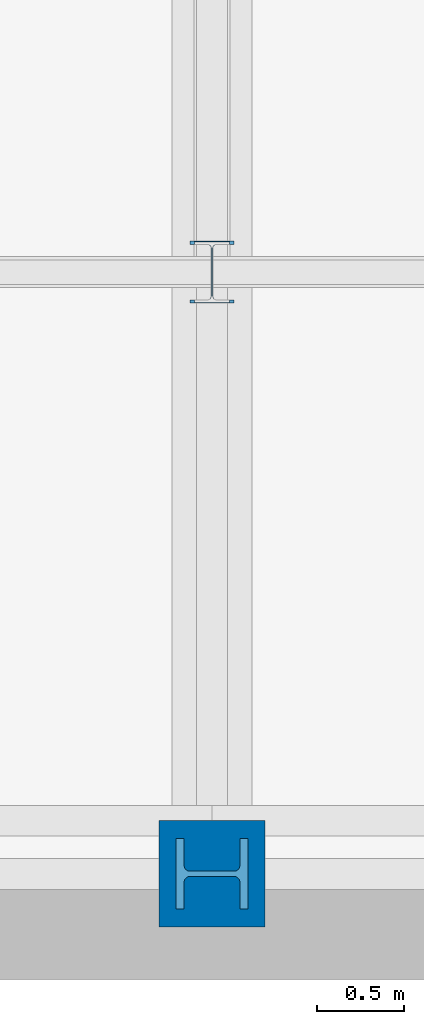
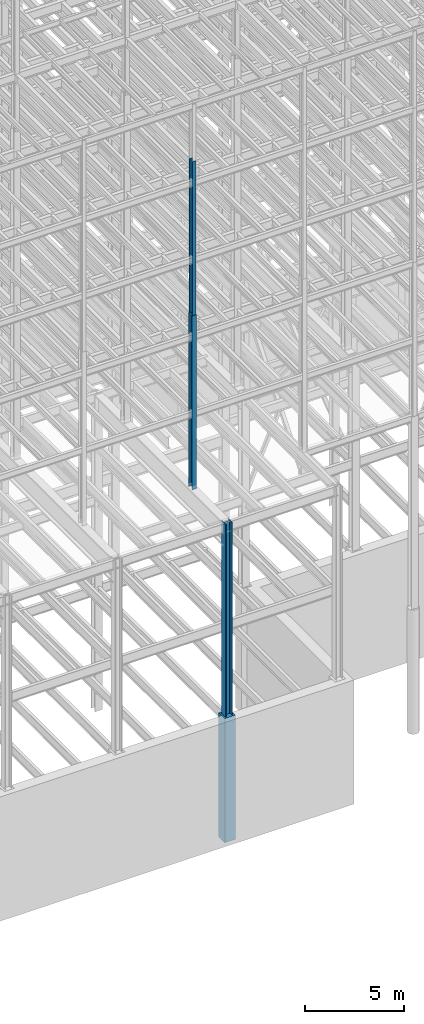
# One storey, part 22 of 150: 4 columns.
"""IFC2X3 building model written with IfcOpenShell, lengths in millimetres."""

import ifcopenshell
import ifcopenshell.guid

model = None  # the IFC model being written
_history = None  # IfcOwnerHistory: only IFC2X3 demands one
_inside = {}  # id of a spatial element -> (the spatial element, [elements in it])
_under = {}  # id of a project, library or spatial element -> (it, [spatial elements below it])
_declared = {}  # id of a project -> (the project, [libraries it declares])
_typed = {}  # id of a type object -> (the type object, [elements of that type])
_made_of = {}  # id of a material, layer set ... -> (it, [elements and type objects made of it])


def new_model(schema):
    """Start an empty IFC model of exactly this schema.

    Asked for "IFC4X3", IfcOpenShell would pick the latest addendum, in which some entities
    have other attributes; the version numbers below select the first issue.
    IFC2X3 requires an IfcOwnerHistory on every rooted entity: one is made here for all.
    """
    global model, _history
    if schema == "IFC4X3":
        model = ifcopenshell.file(schema_version=(4, 3, 0, 0))
    else:
        model = ifcopenshell.file(schema=schema)
    _inside.clear()
    _under.clear()
    _declared.clear()
    _typed.clear()
    _made_of.clear()
    _history = None
    if model.schema == "IFC2X3":
        org = make("IfcOrganization", Name="unknown")
        user = make(
            "IfcPersonAndOrganization",
            ThePerson=make("IfcPerson", FamilyName="unknown"),
            TheOrganization=org,
        )
        app = make(
            "IfcApplication",
            ApplicationDeveloper=org,
            Version="unknown",
            ApplicationFullName="unknown",
            ApplicationIdentifier="unknown",
        )
        _history = make(
            "IfcOwnerHistory",
            OwningUser=user,
            OwningApplication=app,
            ChangeAction="ADDED",
            CreationDate=0,
        )
    return model


def make(cls, **values):
    """One entity of the class cls with the attributes given. An attribute that is None is left unset."""
    return model.create_entity(
        cls, **{name: value for name, value in values.items() if value is not None}
    )


def rooted(cls, **values):
    """An entity with a GlobalId (a new one), such as an element, a storey or a relation."""
    return make(cls, GlobalId=ifcopenshell.guid.new(), OwnerHistory=_history, **values)


def si_unit(unit_type, name, prefix=None):
    """IfcSIUnit, for example si_unit("LENGTHUNIT", "METRE", prefix="MILLI")."""
    return make("IfcSIUnit", UnitType=unit_type, Prefix=prefix, Name=name)


def assignment(units):
    """IfcUnitAssignment: the units of a project."""
    return None if units is None else make("IfcUnitAssignment", Units=units)


def point(xyz):
    """IfcCartesianPoint."""
    return None if xyz is None else make("IfcCartesianPoint", Coordinates=xyz)


def direction(xyz):
    """IfcDirection."""
    return None if xyz is None else make("IfcDirection", DirectionRatios=xyz)


def frame(location, z_axis=None, x_axis=None):
    """IfcAxis2Placement3D, a coordinate frame: its origin and axes. An axis left out is left unset."""
    return make(
        "IfcAxis2Placement3D",
        Location=point(location),
        Axis=direction(z_axis),
        RefDirection=direction(x_axis),
    )


def frame_2d(location, x_axis=None):
    """IfcAxis2Placement2D, a coordinate frame in the plane: its origin and x axis."""
    return make(
        "IfcAxis2Placement2D", Location=point(location), RefDirection=direction(x_axis)
    )


def origin_with_axes():
    """The frame at (0, 0, 0) with the z axis (0, 0, 1) and the x axis (1, 0, 0) written out."""
    return frame((0.0, 0.0, 0.0), z_axis=(0.0, 0.0, 1.0), x_axis=(1.0, 0.0, 0.0))


def origin_2d_with_axis():
    """The frame at (0, 0) in the plane with the x axis (1, 0) written out."""
    return frame_2d((0.0, 0.0), x_axis=(1.0, 0.0))


def place(relative_to, where):
    """IfcLocalPlacement: puts the frame where relative to a parent placement (None: the world)."""
    return make(
        "IfcLocalPlacement", PlacementRelTo=relative_to, RelativePlacement=where
    )


def context(
    kind, dimensions, precision=None, world=None, true_north=None, identifier=None
):
    """IfcGeometricRepresentationContext, for example the 3D "Model" context."""
    return make(
        "IfcGeometricRepresentationContext",
        ContextIdentifier=identifier,
        ContextType=kind,
        CoordinateSpaceDimension=dimensions,
        Precision=precision,
        WorldCoordinateSystem=world,
        TrueNorth=true_north,
    )


def subcontext(parent, identifier, kind, view, scale=None):
    """IfcGeometricRepresentationSubContext, for example "Body" below "Model"."""
    return make(
        "IfcGeometricRepresentationSubContext",
        ContextIdentifier=identifier,
        ContextType=kind,
        ParentContext=parent,
        TargetScale=scale,
        TargetView=view,
    )


def project(units=None, contexts=None):
    """IfcProject with its units and contexts."""
    return rooted(
        "IfcProject",
        Name="project",
        RepresentationContexts=contexts,
        UnitsInContext=assignment(units),
    )


def spatial(cls, under=None, at=None, **own):
    """A site, building, storey or space (cls), placed at a placement, below another one or the project."""
    s = rooted(cls, ObjectPlacement=at, **own)
    if under is not None:
        _under.setdefault(under.id(), (under, []))[1].append(s)
    return s


def profile(cls, at=None, kind="AREA", **sizes):
    """A parametric profile (cls). Its sizes go by their IFC names, for example OverallWidth=200.0."""
    return make(cls, ProfileType=kind, Position=at, **sizes)


def rectangle(**sizes):
    """IfcRectangleProfileDef."""
    return profile("IfcRectangleProfileDef", **sizes)


def i_section(**sizes):
    """IfcIShapeProfileDef."""
    return profile("IfcIShapeProfileDef", **sizes)


def extrude(swept, where, along, depth):
    """IfcExtrudedAreaSolid: the profile swept, set in the frame where, extruded along a direction by depth."""
    return make(
        "IfcExtrudedAreaSolid",
        SweptArea=swept,
        Position=where,
        ExtrudedDirection=direction(along),
        Depth=depth,
    )


def shape(context_of_items, identifier, shape_type, items):
    """IfcShapeRepresentation: the items that make up one representation, for example the "Body"."""
    return make(
        "IfcShapeRepresentation",
        ContextOfItems=context_of_items,
        RepresentationIdentifier=identifier,
        RepresentationType=shape_type,
        Items=items,
    )


def material(Name=None, Category=None):
    """IfcMaterial."""
    return make("IfcMaterial", Name=Name, Category=Category)


def made_of(thing, what):
    """Note that an element or type object is made of a material, layer set ...; save() writes the relation."""
    if what is not None:
        _made_of.setdefault(what.id(), (what, []))[1].append(thing)
    return thing


def type_object(cls, material=None, **own):
    """A type object (cls), such as IfcWallType, which elements share."""
    return made_of(rooted(cls, **own), material)


def element(
    cls,
    number,
    at=None,
    inside=None,
    cuts=None,
    type_object=None,
    material=None,
    context=None,
    identifier="Body",
    shape_type=None,
    held_by="IfcProductDefinitionShape",
    body=None,
    shapes=None,
    **own,
):
    """One element of the class cls, such as IfcWall. Its Tag is "e" and its number.

    at: its placement. inside: the storey or other place that contains it. cuts: it is an
    opening in that element (IfcRelVoidsElement). A single representation is given by context,
    identifier, shape_type and body (its items); several are given by shapes. held_by: the class
    of the entity that holds the representations. save() writes the other relations.
    """
    e = rooted(cls, Tag="e%d" % number, ObjectPlacement=at, **own)
    if body is not None:
        shapes = [shape(context, identifier, shape_type, body)]
    if shapes is not None:
        e.Representation = make(held_by, Representations=shapes)
    if inside is not None:
        _inside.setdefault(inside.id(), (inside, []))[1].append(e)
    if cuts is not None:
        rooted(
            "IfcRelVoidsElement", RelatingBuildingElement=cuts, RelatedOpeningElement=e
        )
    if type_object is not None:
        _typed.setdefault(type_object.id(), (type_object, []))[1].append(e)
    return made_of(e, material)


def aggregate(whole, parts):
    """IfcRelAggregates: a whole, such as a stair, and the parts it consists of."""
    return rooted("IfcRelAggregates", RelatingObject=whole, RelatedObjects=parts)


def save(model, path):
    """Write the relations noted so far, then the file.

    IfcRelAggregates (storeys below a building ...), IfcRelContainedInSpatialStructure (elements
    in a storey), IfcRelDefinesByType, IfcRelAssociatesMaterial and IfcRelDeclares: one each for
    every whole, place, type object, material and project.
    """
    for whole, parts in _under.values():
        aggregate(whole, parts)
    for where, things in _inside.values():
        rooted(
            "IfcRelContainedInSpatialStructure",
            RelatedElements=things,
            RelatingStructure=where,
        )
    for kind, things in _typed.values():
        rooted("IfcRelDefinesByType", RelatedObjects=things, RelatingType=kind)
    for what, things in _made_of.values():
        rooted("IfcRelAssociatesMaterial", RelatedObjects=things, RelatingMaterial=what)
    for by, libraries in _declared.values():
        rooted("IfcRelDeclares", RelatingContext=by, RelatedDefinitions=libraries)
    model.write(path)


model = new_model("IFC2X3")

# Units and contexts
model_context = context("Model", 3, precision=1e-05, world=origin_with_axes())
body_context = subcontext(model_context, "Body", "Model", "MODEL_VIEW")
ifc_project = project(units=[si_unit("LENGTHUNIT", "METRE", prefix="MILLI"), si_unit("AREAUNIT", "SQUARE_METRE"), si_unit("VOLUMEUNIT", "CUBIC_METRE"), si_unit("MASSUNIT", "GRAM", prefix="KILO"), si_unit("TIMEUNIT", "SECOND"), si_unit("PLANEANGLEUNIT", "RADIAN"), si_unit("SOLIDANGLEUNIT", "STERADIAN"), si_unit("THERMODYNAMICTEMPERATUREUNIT", "DEGREE_CELSIUS"), si_unit("LUMINOUSINTENSITYUNIT", "LUMEN")], contexts=[model_context])

# Site, building, storey
site_placement = place(None, origin_with_axes())
site = spatial("IfcSite", under=ifc_project, at=site_placement, CompositionType="ELEMENT")
building_placement = place(site_placement, origin_with_axes())
building = spatial("IfcBuilding", under=site, at=building_placement, Name="Undefined", CompositionType="ELEMENT")
storey_placement = place(building_placement, origin_with_axes())
storey = spatial("IfcBuildingStorey", under=building, at=storey_placement, Name="Undefined", CompositionType="ELEMENT", Elevation=0.0)

# Columns
ifc_material_1 = material(Name="STEEL/A992")
column_type_1 = type_object("IfcColumnType", Name="W14X53", PredefinedType="NOTDEFINED")
column_1_placement = place(storey_placement, frame((37388.8, 3454.39999999999, 46253.4), z_axis=(0.0, 0.0, 1.0), x_axis=(1.0, 0.0, 0.0)))
element("IfcColumn", 1, at=column_1_placement, inside=storey, type_object=column_type_1, material=ifc_material_1, Name="COLUMN", ObjectType="W14X53", context=body_context, shape_type="SweptSolid", body=[
    extrude(i_section(OverallWidth=203.2, OverallDepth=352.425, WebThickness=9.5249, FlangeThickness=16.764, FilletRadius=21.336, at=origin_2d_with_axis()), frame((0.0, 0.0, 9448.8), z_axis=(0.0, 0.0, -1.0), x_axis=(-1.0, 0.0, 0.0)), (0.0, 0.0, 1.0), 9448.8),
])
column_type_2 = type_object("IfcColumnType", Name="W14X68", PredefinedType="NOTDEFINED")
column_2_placement = place(storey_placement, frame((37388.8, 3454.39999999999, 35585.4), z_axis=(0.0, 0.0, 1.0), x_axis=(1.0, 0.0, 0.0)))
element("IfcColumn", 2, at=column_2_placement, inside=storey, type_object=column_type_2, material=ifc_material_1, Name="COLUMN", ObjectType="W14X68", context=body_context, shape_type="SweptSolid", body=[
    extrude(i_section(OverallWidth=254.0, OverallDepth=355.6, WebThickness=11.1125, FlangeThickness=18.288, FilletRadius=21.3994, at=origin_2d_with_axis()), frame((0.0, 0.0, 10667.9989332), z_axis=(0.0, 0.0, -1.0), x_axis=(-1.0, 0.0, 0.0)), (0.0, 0.0, 1.0), 10667.9989332),
])
column_type_3 = type_object("IfcColumnType", Name="W14X257", PredefinedType="NOTDEFINED")
column_3_placement = place(storey_placement, frame((37388.8, 0.0, 22707.6), z_axis=(0.0, 0.0, 1.0), x_axis=(1.0, 0.0, 0.0)))
element("IfcColumn", 3, at=column_3_placement, inside=storey, type_object=column_type_3, material=ifc_material_1, Name="COLUMN", ObjectType="W14X257", context=body_context, shape_type="SweptSolid", body=[
    extrude(i_section(OverallWidth=406.4, OverallDepth=415.925, WebThickness=30.1625, FlangeThickness=48.006, FilletRadius=32.9564, at=origin_2d_with_axis()), frame((0.0, 0.0, 12877.8), z_axis=(0.0, 0.0, -1.0), x_axis=(0.0, -1.0, 0.0)), (0.0, 0.0, 1.0), 12877.8),
])
ifc_material_2 = material(Name="CONCRETE/5000")
column_type_4 = type_object("IfcColumnType", PredefinedType="NOTDEFINED")
column_4_placement = place(storey_placement, frame((37388.8, 0.0, 16154.4), z_axis=(0.0, 0.0, 1.0), x_axis=(1.0, 0.0, 0.0)))
element("IfcColumn", 4, at=column_4_placement, inside=storey, type_object=column_type_4, material=ifc_material_2, Name="COLUMN", context=body_context, shape_type="SweptSolid", body=[
    extrude(rectangle(XDim=609.6, YDim=609.6, at=origin_2d_with_axis()), frame((0.0, 0.0, 7620.0), z_axis=(0.0, 0.0, -1.0), x_axis=(0.0, -1.0, 0.0)), (0.0, 0.0, 1.0), 7620.0),
])

save(model, "model.ifc")
